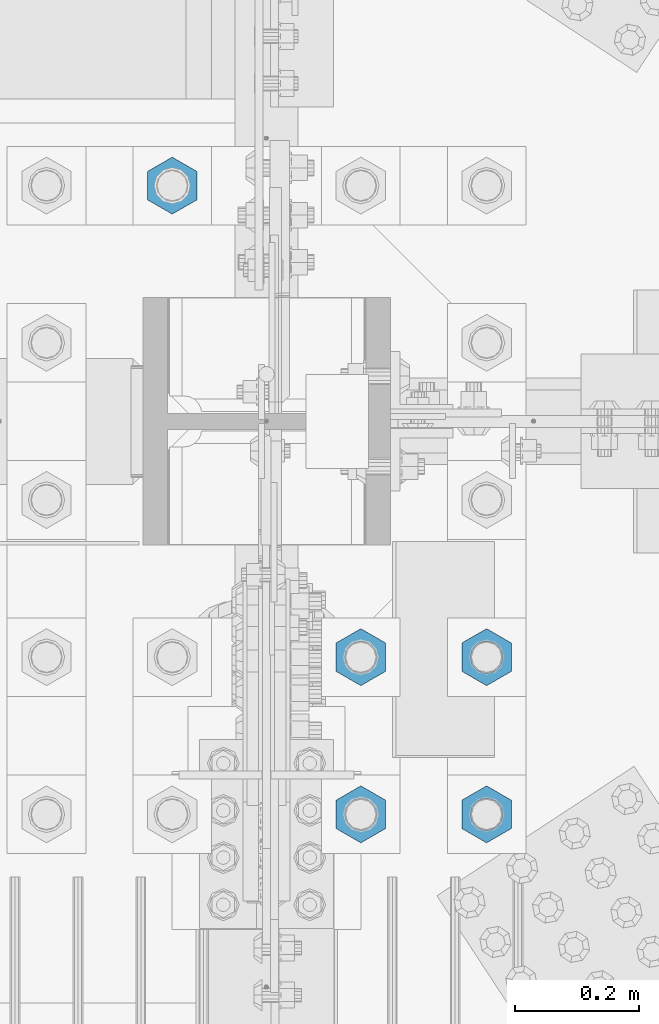
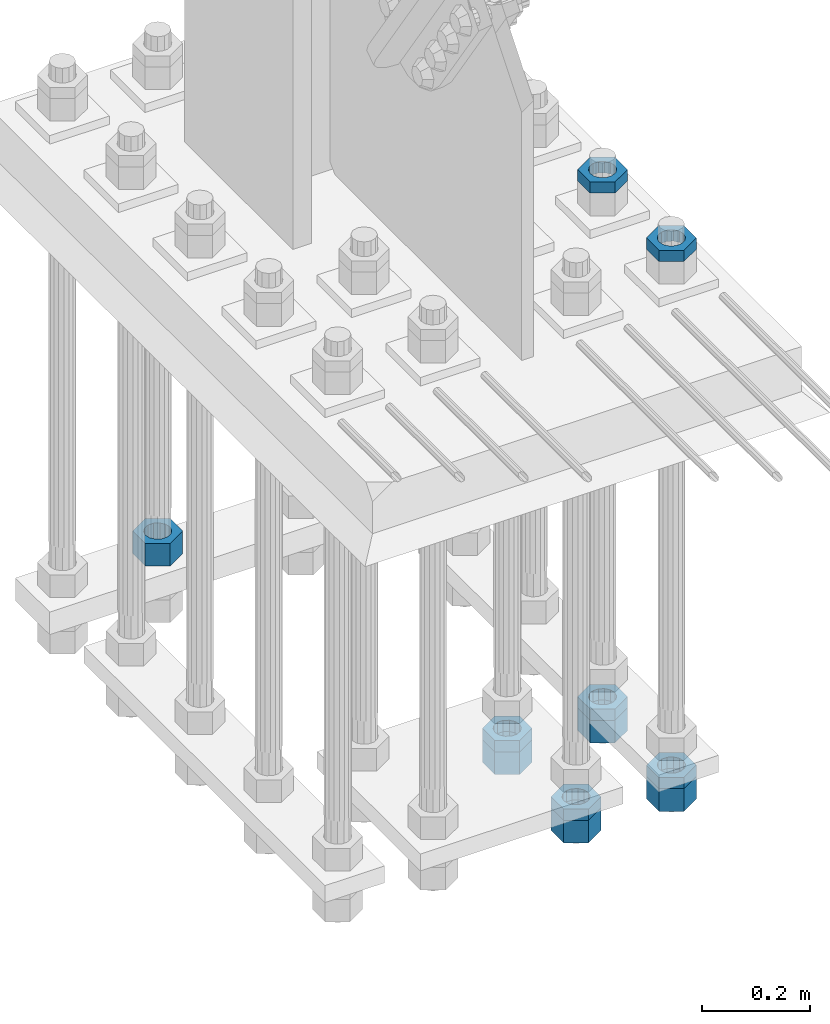
# One storey, part 2213 of 3843: 11 beams, 1 element without a shape of its own.
"""IFC2X3 building model written with IfcOpenShell, lengths in millimetres."""

from ifc_helpers import new_model, si_unit, frame, origin_with_axes, place, context, subcontext, project, spatial, faceted_brep, material, type_object, element, aggregate, save


model = new_model("IFC2X3")

# Units and contexts
model_context = context("Model", 3, precision=1e-05, world=origin_with_axes())
body_context = subcontext(model_context, "Body", "Model", "MODEL_VIEW")
ifc_project = project(units=[si_unit("LENGTHUNIT", "METRE", prefix="MILLI"), si_unit("AREAUNIT", "SQUARE_METRE"), si_unit("VOLUMEUNIT", "CUBIC_METRE"), si_unit("MASSUNIT", "GRAM", prefix="KILO"), si_unit("TIMEUNIT", "SECOND"), si_unit("PLANEANGLEUNIT", "RADIAN"), si_unit("SOLIDANGLEUNIT", "STERADIAN"), si_unit("THERMODYNAMICTEMPERATUREUNIT", "DEGREE_CELSIUS"), si_unit("LUMINOUSINTENSITYUNIT", "LUMEN")], contexts=[model_context])

# Site, building, storey
site_placement = place(None, origin_with_axes())
site = spatial("IfcSite", under=ifc_project, at=site_placement, CompositionType="ELEMENT")
building_placement = place(site_placement, origin_with_axes())
building = spatial("IfcBuilding", under=site, at=building_placement, Name="Undefined", CompositionType="ELEMENT")
storey_placement = place(building_placement, origin_with_axes())
storey = spatial("IfcBuildingStorey", under=building, at=storey_placement, Name="Undefined", CompositionType="ELEMENT", Elevation=0.0)

# Assembly, beams
assembly_placement = place(storey_placement, origin_with_axes())
assembly = element("IfcElementAssembly", 1, at=assembly_placement, inside=storey, Name="TEMPLATE", AssemblyPlace="NOTDEFINED", PredefinedType="RIGID_FRAME")
ifc_material = material(Name="STEEL/A572-50")
beam_type_1 = type_object("IfcBeamType", Name="2_HALF_NUT", PredefinedType="NOTDEFINED")
beam_1_placement = place(assembly_placement, frame((36931.6, 58534.3, 30257.75), z_axis=(-1.0, 0.0, 0.0), x_axis=(0.0, 0.0, -1.0)))
beam_1 = element("IfcBeam", 2, at=beam_1_placement, type_object=beam_type_1, material=ifc_material, Name="NUT", ObjectType="2_HALF_NUT", context=body_context, shape_type="Brep", body=[
    faceted_brep([(0.0, -46.0369987487793, 0.0), (0.0, -23.0184993743896, -39.869213104248), (25.4000000000015, -23.0184993743896, -39.869213104248), (25.4000000000015, -46.0369987487793, 0.0), (0.0, 23.0184993743896, -39.869213104248), (25.4000000000015, 23.0184993743896, -39.869213104248), (0.0, 46.0369987487793, 0.0), (25.4000000000015, 46.0369987487793, 0.0), (0.0, 23.0184993743896, 39.869213104248), (25.4000000000015, 23.0184993743896, 39.869213104248), (0.0, -23.0184993743896, 39.869213104248), (25.4000000000015, -23.0184993743896, 39.869213104248), (0.0, 0.0, 26.1940002441406), (0.0, 11.3650617044477, 23.5999013092805), (25.4000000000015, 11.3650617044477, 23.5999013092805), (25.4000000000015, 0.0, 26.1940002441406), (0.0, 20.4791109456419, 16.3316083006721), (25.4000000000015, 20.4791109456419, 16.3316083006721), (0.0, 25.5370200498292, 5.82867859874386), (25.4000000000015, 25.5370200498292, 5.82867859874386), (0.0, 25.5370200498292, -5.82867859874386), (25.4000000000015, 25.5370200498292, -5.82867859874386), (0.0, 20.4791109456419, -16.3316083006721), (25.4000000000015, 20.4791109456419, -16.3316083006721), (0.0, 11.3650617044477, -23.5999013092805), (25.4000000000015, 11.3650617044477, -23.5999013092805), (0.0, 0.0, -26.1940002441406), (25.4000000000015, 0.0, -26.1940002441406), (0.0, -11.3650617044477, -23.5999013092805), (25.4000000000015, -11.3650617044477, -23.5999013092805), (0.0, -20.4791109456419, -16.3316083006721), (25.4000000000015, -20.4791109456419, -16.3316083006721), (0.0, -25.5370200498292, -5.82867859874386), (25.4000000000015, -25.5370200498292, -5.82867859874386), (0.0, -25.5370200498292, 5.82867859874386), (25.4000000000015, -25.5370200498292, 5.82867859874386), (0.0, -20.4791109456419, 16.3316083006721), (25.4000000000015, -20.4791109456419, 16.3316083006721), (0.0, -11.3650617044477, 23.5999013092805), (25.4000000000015, -11.3650617044477, 23.5999013092805)], [[[0, 1, 2, 3]], [[1, 4, 5, 2]], [[4, 6, 7, 5]], [[6, 8, 9, 7]], [[8, 10, 11, 9]], [[10, 0, 3, 11]], [[12, 13, 14, 15]], [[13, 16, 17, 14]], [[16, 18, 19, 17]], [[18, 20, 21, 19]], [[20, 22, 23, 21]], [[22, 24, 25, 23]], [[24, 26, 27, 25]], [[26, 28, 29, 27]], [[28, 30, 31, 29]], [[30, 32, 33, 31]], [[32, 34, 35, 33]], [[34, 36, 37, 35]], [[36, 38, 39, 37]], [[38, 12, 15, 39]], [[5, 7, 9, 11, 3, 2], [17, 19, 21, 23, 25, 27, 29, 31, 33, 35, 37, 39, 15, 14]], [[10, 8, 6, 4, 1, 0], [38, 36, 34, 32, 30, 28, 26, 24, 22, 20, 18, 16, 13, 12]]]),
])
beam_2_placement = place(assembly_placement, frame((36931.6, 58280.3, 30257.75), z_axis=(-1.0, 0.0, 0.0), x_axis=(0.0, 0.0, -1.0)))
beam_2 = element("IfcBeam", 3, at=beam_2_placement, type_object=beam_type_1, material=ifc_material, Name="NUT", ObjectType="2_HALF_NUT", context=body_context, shape_type="Brep", body=[
    faceted_brep([(0.0, -46.0369987487793, 0.0), (0.0, -23.0184993743896, -39.869213104248), (25.4000000000015, -23.0184993743896, -39.869213104248), (25.4000000000015, -46.0369987487793, 0.0), (0.0, 23.0184993743896, -39.869213104248), (25.4000000000015, 23.0184993743896, -39.869213104248), (0.0, 46.0369987487793, 0.0), (25.4000000000015, 46.0369987487793, 0.0), (0.0, 23.0184993743896, 39.869213104248), (25.4000000000015, 23.0184993743896, 39.869213104248), (0.0, -23.0184993743896, 39.869213104248), (25.4000000000015, -23.0184993743896, 39.869213104248), (0.0, 0.0, 26.1940002441406), (0.0, 11.3650617044477, 23.5999013092805), (25.4000000000015, 11.3650617044477, 23.5999013092805), (25.4000000000015, 0.0, 26.1940002441406), (0.0, 20.4791109456419, 16.3316083006721), (25.4000000000015, 20.4791109456419, 16.3316083006721), (0.0, 25.5370200498292, 5.82867859874386), (25.4000000000015, 25.5370200498292, 5.82867859874386), (0.0, 25.5370200498292, -5.82867859874386), (25.4000000000015, 25.5370200498292, -5.82867859874386), (0.0, 20.4791109456419, -16.3316083006721), (25.4000000000015, 20.4791109456419, -16.3316083006721), (0.0, 11.3650617044477, -23.5999013092805), (25.4000000000015, 11.3650617044477, -23.5999013092805), (0.0, 0.0, -26.1940002441406), (25.4000000000015, 0.0, -26.1940002441406), (0.0, -11.3650617044477, -23.5999013092805), (25.4000000000015, -11.3650617044477, -23.5999013092805), (0.0, -20.4791109456419, -16.3316083006721), (25.4000000000015, -20.4791109456419, -16.3316083006721), (0.0, -25.5370200498292, -5.82867859874386), (25.4000000000015, -25.5370200498292, -5.82867859874386), (0.0, -25.5370200498292, 5.82867859874386), (25.4000000000015, -25.5370200498292, 5.82867859874386), (0.0, -20.4791109456419, 16.3316083006721), (25.4000000000015, -20.4791109456419, 16.3316083006721), (0.0, -11.3650617044477, 23.5999013092805), (25.4000000000015, -11.3650617044477, 23.5999013092805)], [[[0, 1, 2, 3]], [[1, 4, 5, 2]], [[4, 6, 7, 5]], [[6, 8, 9, 7]], [[8, 10, 11, 9]], [[10, 0, 3, 11]], [[12, 13, 14, 15]], [[13, 16, 17, 14]], [[16, 18, 19, 17]], [[18, 20, 21, 19]], [[20, 22, 23, 21]], [[22, 24, 25, 23]], [[24, 26, 27, 25]], [[26, 28, 29, 27]], [[28, 30, 31, 29]], [[30, 32, 33, 31]], [[32, 34, 35, 33]], [[34, 36, 37, 35]], [[36, 38, 39, 37]], [[38, 12, 15, 39]], [[5, 7, 9, 11, 3, 2], [17, 19, 21, 23, 25, 27, 29, 31, 33, 35, 37, 39, 15, 14]], [[10, 8, 6, 4, 1, 0], [38, 36, 34, 32, 30, 28, 26, 24, 22, 20, 18, 16, 13, 12]]]),
])
beam_3_placement = place(assembly_placement, frame((36728.4, 58534.3, 29070.3), z_axis=(-1.0, 0.0, 0.0), x_axis=(0.0, 0.0, -1.0)))
beam_3 = element("IfcBeam", 4, at=beam_3_placement, type_object=beam_type_1, material=ifc_material, Name="NUT", ObjectType="2_HALF_NUT", context=body_context, shape_type="Brep", body=[
    faceted_brep([(0.0, -46.0369987487793, 0.0), (0.0, -23.0184993743896, -39.869213104248), (25.4000000000015, -23.0184993743896, -39.869213104248), (25.4000000000015, -46.0369987487793, 0.0), (0.0, 23.0184993743896, -39.869213104248), (25.4000000000015, 23.0184993743896, -39.869213104248), (0.0, 46.0369987487793, 0.0), (25.4000000000015, 46.0369987487793, 0.0), (0.0, 23.0184993743896, 39.869213104248), (25.4000000000015, 23.0184993743896, 39.869213104248), (0.0, -23.0184993743896, 39.869213104248), (25.4000000000015, -23.0184993743896, 39.869213104248), (0.0, 0.0, 26.1940002441406), (0.0, 11.3650617044477, 23.5999013092805), (25.4000000000015, 11.3650617044477, 23.5999013092805), (25.4000000000015, 0.0, 26.1940002441406), (0.0, 20.4791109456419, 16.3316083006721), (25.4000000000015, 20.4791109456419, 16.3316083006721), (0.0, 25.5370200498292, 5.82867859874386), (25.4000000000015, 25.5370200498292, 5.82867859874386), (0.0, 25.5370200498292, -5.82867859874386), (25.4000000000015, 25.5370200498292, -5.82867859874386), (0.0, 20.4791109456419, -16.3316083006721), (25.4000000000015, 20.4791109456419, -16.3316083006721), (0.0, 11.3650617044477, -23.5999013092805), (25.4000000000015, 11.3650617044477, -23.5999013092805), (0.0, 0.0, -26.1940002441406), (25.4000000000015, 0.0, -26.1940002441406), (0.0, -11.3650617044477, -23.5999013092805), (25.4000000000015, -11.3650617044477, -23.5999013092805), (0.0, -20.4791109456419, -16.3316083006721), (25.4000000000015, -20.4791109456419, -16.3316083006721), (0.0, -25.5370200498292, -5.82867859874386), (25.4000000000015, -25.5370200498292, -5.82867859874386), (0.0, -25.5370200498292, 5.82867859874386), (25.4000000000015, -25.5370200498292, 5.82867859874386), (0.0, -20.4791109456419, 16.3316083006721), (25.4000000000015, -20.4791109456419, 16.3316083006721), (0.0, -11.3650617044477, 23.5999013092805), (25.4000000000015, -11.3650617044477, 23.5999013092805)], [[[0, 1, 2, 3]], [[1, 4, 5, 2]], [[4, 6, 7, 5]], [[6, 8, 9, 7]], [[8, 10, 11, 9]], [[10, 0, 3, 11]], [[12, 13, 14, 15]], [[13, 16, 17, 14]], [[16, 18, 19, 17]], [[18, 20, 21, 19]], [[20, 22, 23, 21]], [[22, 24, 25, 23]], [[24, 26, 27, 25]], [[26, 28, 29, 27]], [[28, 30, 31, 29]], [[30, 32, 33, 31]], [[32, 34, 35, 33]], [[34, 36, 37, 35]], [[36, 38, 39, 37]], [[38, 12, 15, 39]], [[5, 7, 9, 11, 3, 2], [17, 19, 21, 23, 25, 27, 29, 31, 33, 35, 37, 39, 15, 14]], [[10, 8, 6, 4, 1, 0], [38, 36, 34, 32, 30, 28, 26, 24, 22, 20, 18, 16, 13, 12]]]),
])
beam_4_placement = place(assembly_placement, frame((36728.4, 58280.3, 29070.3), z_axis=(-1.0, 0.0, 0.0), x_axis=(0.0, 0.0, -1.0)))
beam_4 = element("IfcBeam", 5, at=beam_4_placement, type_object=beam_type_1, material=ifc_material, Name="NUT", ObjectType="2_HALF_NUT", context=body_context, shape_type="Brep", body=[
    faceted_brep([(0.0, -46.0369987487793, 0.0), (0.0, -23.0184993743896, -39.869213104248), (25.4000000000015, -23.0184993743896, -39.869213104248), (25.4000000000015, -46.0369987487793, 0.0), (0.0, 23.0184993743896, -39.869213104248), (25.4000000000015, 23.0184993743896, -39.869213104248), (0.0, 46.0369987487793, 0.0), (25.4000000000015, 46.0369987487793, 0.0), (0.0, 23.0184993743896, 39.869213104248), (25.4000000000015, 23.0184993743896, 39.869213104248), (0.0, -23.0184993743896, 39.869213104248), (25.4000000000015, -23.0184993743896, 39.869213104248), (0.0, 0.0, 26.1940002441406), (0.0, 11.3650617044477, 23.5999013092805), (25.4000000000015, 11.3650617044477, 23.5999013092805), (25.4000000000015, 0.0, 26.1940002441406), (0.0, 20.4791109456419, 16.3316083006721), (25.4000000000015, 20.4791109456419, 16.3316083006721), (0.0, 25.5370200498292, 5.82867859874386), (25.4000000000015, 25.5370200498292, 5.82867859874386), (0.0, 25.5370200498292, -5.82867859874386), (25.4000000000015, 25.5370200498292, -5.82867859874386), (0.0, 20.4791109456419, -16.3316083006721), (25.4000000000015, 20.4791109456419, -16.3316083006721), (0.0, 11.3650617044477, -23.5999013092805), (25.4000000000015, 11.3650617044477, -23.5999013092805), (0.0, 0.0, -26.1940002441406), (25.4000000000015, 0.0, -26.1940002441406), (0.0, -11.3650617044477, -23.5999013092805), (25.4000000000015, -11.3650617044477, -23.5999013092805), (0.0, -20.4791109456419, -16.3316083006721), (25.4000000000015, -20.4791109456419, -16.3316083006721), (0.0, -25.5370200498292, -5.82867859874386), (25.4000000000015, -25.5370200498292, -5.82867859874386), (0.0, -25.5370200498292, 5.82867859874386), (25.4000000000015, -25.5370200498292, 5.82867859874386), (0.0, -20.4791109456419, 16.3316083006721), (25.4000000000015, -20.4791109456419, 16.3316083006721), (0.0, -11.3650617044477, 23.5999013092805), (25.4000000000015, -11.3650617044477, 23.5999013092805)], [[[0, 1, 2, 3]], [[1, 4, 5, 2]], [[4, 6, 7, 5]], [[6, 8, 9, 7]], [[8, 10, 11, 9]], [[10, 0, 3, 11]], [[12, 13, 14, 15]], [[13, 16, 17, 14]], [[16, 18, 19, 17]], [[18, 20, 21, 19]], [[20, 22, 23, 21]], [[22, 24, 25, 23]], [[24, 26, 27, 25]], [[26, 28, 29, 27]], [[28, 30, 31, 29]], [[30, 32, 33, 31]], [[32, 34, 35, 33]], [[34, 36, 37, 35]], [[36, 38, 39, 37]], [[38, 12, 15, 39]], [[5, 7, 9, 11, 3, 2], [17, 19, 21, 23, 25, 27, 29, 31, 33, 35, 37, 39, 15, 14]], [[10, 8, 6, 4, 1, 0], [38, 36, 34, 32, 30, 28, 26, 24, 22, 20, 18, 16, 13, 12]]]),
])
beam_5_placement = place(assembly_placement, frame((36931.6, 58534.3, 29070.3), z_axis=(-1.0, 0.0, 0.0), x_axis=(0.0, 0.0, -1.0)))
beam_5 = element("IfcBeam", 6, at=beam_5_placement, type_object=beam_type_1, material=ifc_material, Name="NUT", ObjectType="2_HALF_NUT", context=body_context, shape_type="Brep", body=[
    faceted_brep([(0.0, -46.0369987487793, 0.0), (0.0, -23.0184993743896, -39.869213104248), (25.4000000000015, -23.0184993743896, -39.869213104248), (25.4000000000015, -46.0369987487793, 0.0), (0.0, 23.0184993743896, -39.869213104248), (25.4000000000015, 23.0184993743896, -39.869213104248), (0.0, 46.0369987487793, 0.0), (25.4000000000015, 46.0369987487793, 0.0), (0.0, 23.0184993743896, 39.869213104248), (25.4000000000015, 23.0184993743896, 39.869213104248), (0.0, -23.0184993743896, 39.869213104248), (25.4000000000015, -23.0184993743896, 39.869213104248), (0.0, 0.0, 26.1940002441406), (0.0, 11.3650617044477, 23.5999013092805), (25.4000000000015, 11.3650617044477, 23.5999013092805), (25.4000000000015, 0.0, 26.1940002441406), (0.0, 20.4791109456419, 16.3316083006721), (25.4000000000015, 20.4791109456419, 16.3316083006721), (0.0, 25.5370200498292, 5.82867859874386), (25.4000000000015, 25.5370200498292, 5.82867859874386), (0.0, 25.5370200498292, -5.82867859874386), (25.4000000000015, 25.5370200498292, -5.82867859874386), (0.0, 20.4791109456419, -16.3316083006721), (25.4000000000015, 20.4791109456419, -16.3316083006721), (0.0, 11.3650617044477, -23.5999013092805), (25.4000000000015, 11.3650617044477, -23.5999013092805), (0.0, 0.0, -26.1940002441406), (25.4000000000015, 0.0, -26.1940002441406), (0.0, -11.3650617044477, -23.5999013092805), (25.4000000000015, -11.3650617044477, -23.5999013092805), (0.0, -20.4791109456419, -16.3316083006721), (25.4000000000015, -20.4791109456419, -16.3316083006721), (0.0, -25.5370200498292, -5.82867859874386), (25.4000000000015, -25.5370200498292, -5.82867859874386), (0.0, -25.5370200498292, 5.82867859874386), (25.4000000000015, -25.5370200498292, 5.82867859874386), (0.0, -20.4791109456419, 16.3316083006721), (25.4000000000015, -20.4791109456419, 16.3316083006721), (0.0, -11.3650617044477, 23.5999013092805), (25.4000000000015, -11.3650617044477, 23.5999013092805)], [[[0, 1, 2, 3]], [[1, 4, 5, 2]], [[4, 6, 7, 5]], [[6, 8, 9, 7]], [[8, 10, 11, 9]], [[10, 0, 3, 11]], [[12, 13, 14, 15]], [[13, 16, 17, 14]], [[16, 18, 19, 17]], [[18, 20, 21, 19]], [[20, 22, 23, 21]], [[22, 24, 25, 23]], [[24, 26, 27, 25]], [[26, 28, 29, 27]], [[28, 30, 31, 29]], [[30, 32, 33, 31]], [[32, 34, 35, 33]], [[34, 36, 37, 35]], [[36, 38, 39, 37]], [[38, 12, 15, 39]], [[5, 7, 9, 11, 3, 2], [17, 19, 21, 23, 25, 27, 29, 31, 33, 35, 37, 39, 15, 14]], [[10, 8, 6, 4, 1, 0], [38, 36, 34, 32, 30, 28, 26, 24, 22, 20, 18, 16, 13, 12]]]),
])
beam_6_placement = place(assembly_placement, frame((36931.6, 58280.3, 29070.3), z_axis=(-1.0, 0.0, 0.0), x_axis=(0.0, 0.0, -1.0)))
beam_6 = element("IfcBeam", 7, at=beam_6_placement, type_object=beam_type_1, material=ifc_material, Name="NUT", ObjectType="2_HALF_NUT", context=body_context, shape_type="Brep", body=[
    faceted_brep([(0.0, -46.0369987487793, 0.0), (0.0, -23.0184993743896, -39.869213104248), (25.4000000000015, -23.0184993743896, -39.869213104248), (25.4000000000015, -46.0369987487793, 0.0), (0.0, 23.0184993743896, -39.869213104248), (25.4000000000015, 23.0184993743896, -39.869213104248), (0.0, 46.0369987487793, 0.0), (25.4000000000015, 46.0369987487793, 0.0), (0.0, 23.0184993743896, 39.869213104248), (25.4000000000015, 23.0184993743896, 39.869213104248), (0.0, -23.0184993743896, 39.869213104248), (25.4000000000015, -23.0184993743896, 39.869213104248), (0.0, 0.0, 26.1940002441406), (0.0, 11.3650617044477, 23.5999013092805), (25.4000000000015, 11.3650617044477, 23.5999013092805), (25.4000000000015, 0.0, 26.1940002441406), (0.0, 20.4791109456419, 16.3316083006721), (25.4000000000015, 20.4791109456419, 16.3316083006721), (0.0, 25.5370200498292, 5.82867859874386), (25.4000000000015, 25.5370200498292, 5.82867859874386), (0.0, 25.5370200498292, -5.82867859874386), (25.4000000000015, 25.5370200498292, -5.82867859874386), (0.0, 20.4791109456419, -16.3316083006721), (25.4000000000015, 20.4791109456419, -16.3316083006721), (0.0, 11.3650617044477, -23.5999013092805), (25.4000000000015, 11.3650617044477, -23.5999013092805), (0.0, 0.0, -26.1940002441406), (25.4000000000015, 0.0, -26.1940002441406), (0.0, -11.3650617044477, -23.5999013092805), (25.4000000000015, -11.3650617044477, -23.5999013092805), (0.0, -20.4791109456419, -16.3316083006721), (25.4000000000015, -20.4791109456419, -16.3316083006721), (0.0, -25.5370200498292, -5.82867859874386), (25.4000000000015, -25.5370200498292, -5.82867859874386), (0.0, -25.5370200498292, 5.82867859874386), (25.4000000000015, -25.5370200498292, 5.82867859874386), (0.0, -20.4791109456419, 16.3316083006721), (25.4000000000015, -20.4791109456419, 16.3316083006721), (0.0, -11.3650617044477, 23.5999013092805), (25.4000000000015, -11.3650617044477, 23.5999013092805)], [[[0, 1, 2, 3]], [[1, 4, 5, 2]], [[4, 6, 7, 5]], [[6, 8, 9, 7]], [[8, 10, 11, 9]], [[10, 0, 3, 11]], [[12, 13, 14, 15]], [[13, 16, 17, 14]], [[16, 18, 19, 17]], [[18, 20, 21, 19]], [[20, 22, 23, 21]], [[22, 24, 25, 23]], [[24, 26, 27, 25]], [[26, 28, 29, 27]], [[28, 30, 31, 29]], [[30, 32, 33, 31]], [[32, 34, 35, 33]], [[34, 36, 37, 35]], [[36, 38, 39, 37]], [[38, 12, 15, 39]], [[5, 7, 9, 11, 3, 2], [17, 19, 21, 23, 25, 27, 29, 31, 33, 35, 37, 39, 15, 14]], [[10, 8, 6, 4, 1, 0], [38, 36, 34, 32, 30, 28, 26, 24, 22, 20, 18, 16, 13, 12]]]),
])
beam_type_2 = type_object("IfcBeamType", Name="2_HEAVY_HEX_NUT", PredefinedType="NOTDEFINED")
beam_7_placement = place(assembly_placement, frame((36423.6, 59296.3, 29159.2), z_axis=(1.0, 0.0, 0.0), x_axis=(0.0, 0.0, -1.0)))
beam_7 = element("IfcBeam", 8, at=beam_7_placement, type_object=beam_type_2, material=ifc_material, Name="NUT", ObjectType="2_HEAVY_HEX_NUT", context=body_context, shape_type="Brep", body=[
    faceted_brep([(0.0, -46.0369987487793, 0.0), (0.0, -23.0184993743896, -39.869213104248), (50.7999999999993, -23.0184993743896, -39.869213104248), (50.7999999999993, -46.0369987487793, 0.0), (0.0, 23.0184993743896, -39.869213104248), (50.7999999999993, 23.0184993743896, -39.869213104248), (0.0, 46.0369987487793, 0.0), (50.7999999999993, 46.0369987487793, 0.0), (0.0, 23.0184993743896, 39.869213104248), (50.7999999999993, 23.0184993743896, 39.869213104248), (0.0, -23.0184993743896, 39.869213104248), (50.7999999999993, -23.0184993743896, 39.869213104248), (0.0, 0.0, 26.1940002441406), (0.0, 11.3650617044477, 23.5999013092805), (50.7999999999993, 11.3650617044477, 23.5999013092805), (50.7999999999993, 0.0, 26.1940002441406), (0.0, 20.4791109456419, 16.3316083006721), (50.7999999999993, 20.4791109456419, 16.3316083006721), (0.0, 25.5370200498292, 5.82867859874386), (50.7999999999993, 25.5370200498292, 5.82867859874386), (0.0, 25.5370200498292, -5.82867859874386), (50.7999999999993, 25.5370200498292, -5.82867859874386), (0.0, 20.4791109456419, -16.3316083006721), (50.7999999999993, 20.4791109456419, -16.3316083006721), (0.0, 11.3650617044477, -23.5999013092805), (50.7999999999993, 11.3650617044477, -23.5999013092805), (0.0, 0.0, -26.1940002441406), (50.7999999999993, 0.0, -26.1940002441406), (0.0, -11.3650617044477, -23.5999013092805), (50.7999999999993, -11.3650617044477, -23.5999013092805), (0.0, -20.4791109456419, -16.3316083006721), (50.7999999999993, -20.4791109456419, -16.3316083006721), (0.0, -25.5370200498292, -5.82867859874386), (50.7999999999993, -25.5370200498292, -5.82867859874386), (0.0, -25.5370200498292, 5.82867859874386), (50.7999999999993, -25.5370200498292, 5.82867859874386), (0.0, -20.4791109456419, 16.3316083006721), (50.7999999999993, -20.4791109456419, 16.3316083006721), (0.0, -11.3650617044477, 23.5999013092805), (50.7999999999993, -11.3650617044477, 23.5999013092805)], [[[0, 1, 2, 3]], [[1, 4, 5, 2]], [[4, 6, 7, 5]], [[6, 8, 9, 7]], [[8, 10, 11, 9]], [[10, 0, 3, 11]], [[12, 13, 14, 15]], [[13, 16, 17, 14]], [[16, 18, 19, 17]], [[18, 20, 21, 19]], [[20, 22, 23, 21]], [[22, 24, 25, 23]], [[24, 26, 27, 25]], [[26, 28, 29, 27]], [[28, 30, 31, 29]], [[30, 32, 33, 31]], [[32, 34, 35, 33]], [[34, 36, 37, 35]], [[36, 38, 39, 37]], [[38, 12, 15, 39]], [[5, 7, 9, 11, 3, 2], [17, 19, 21, 23, 25, 27, 29, 31, 33, 35, 37, 39, 15, 14]], [[10, 8, 6, 4, 1, 0], [38, 36, 34, 32, 30, 28, 26, 24, 22, 20, 18, 16, 13, 12]]]),
])
beam_8_placement = place(assembly_placement, frame((36728.4, 58534.3, 29044.9), z_axis=(-1.0, 0.0, 0.0), x_axis=(0.0, 0.0, -1.0)))
beam_8 = element("IfcBeam", 9, at=beam_8_placement, type_object=beam_type_2, material=ifc_material, Name="NUT", ObjectType="2_HEAVY_HEX_NUT", context=body_context, shape_type="Brep", body=[
    faceted_brep([(0.0, -46.0369987487793, 0.0), (0.0, -23.0184993743896, -39.869213104248), (50.7999999999993, -23.0184993743896, -39.869213104248), (50.7999999999993, -46.0369987487793, 0.0), (0.0, 23.0184993743896, -39.869213104248), (50.7999999999993, 23.0184993743896, -39.869213104248), (0.0, 46.0369987487793, 0.0), (50.7999999999993, 46.0369987487793, 0.0), (0.0, 23.0184993743896, 39.869213104248), (50.7999999999993, 23.0184993743896, 39.869213104248), (0.0, -23.0184993743896, 39.869213104248), (50.7999999999993, -23.0184993743896, 39.869213104248), (0.0, 0.0, 26.1940002441406), (0.0, 11.3650617044477, 23.5999013092805), (50.7999999999993, 11.3650617044477, 23.5999013092805), (50.7999999999993, 0.0, 26.1940002441406), (0.0, 20.4791109456419, 16.3316083006721), (50.7999999999993, 20.4791109456419, 16.3316083006721), (0.0, 25.5370200498292, 5.82867859874386), (50.7999999999993, 25.5370200498292, 5.82867859874386), (0.0, 25.5370200498292, -5.82867859874386), (50.7999999999993, 25.5370200498292, -5.82867859874386), (0.0, 20.4791109456419, -16.3316083006721), (50.7999999999993, 20.4791109456419, -16.3316083006721), (0.0, 11.3650617044477, -23.5999013092805), (50.7999999999993, 11.3650617044477, -23.5999013092805), (0.0, 0.0, -26.1940002441406), (50.7999999999993, 0.0, -26.1940002441406), (0.0, -11.3650617044477, -23.5999013092805), (50.7999999999993, -11.3650617044477, -23.5999013092805), (0.0, -20.4791109456419, -16.3316083006721), (50.7999999999993, -20.4791109456419, -16.3316083006721), (0.0, -25.5370200498292, -5.82867859874386), (50.7999999999993, -25.5370200498292, -5.82867859874386), (0.0, -25.5370200498292, 5.82867859874386), (50.7999999999993, -25.5370200498292, 5.82867859874386), (0.0, -20.4791109456419, 16.3316083006721), (50.7999999999993, -20.4791109456419, 16.3316083006721), (0.0, -11.3650617044477, 23.5999013092805), (50.7999999999993, -11.3650617044477, 23.5999013092805)], [[[0, 1, 2, 3]], [[1, 4, 5, 2]], [[4, 6, 7, 5]], [[6, 8, 9, 7]], [[8, 10, 11, 9]], [[10, 0, 3, 11]], [[12, 13, 14, 15]], [[13, 16, 17, 14]], [[16, 18, 19, 17]], [[18, 20, 21, 19]], [[20, 22, 23, 21]], [[22, 24, 25, 23]], [[24, 26, 27, 25]], [[26, 28, 29, 27]], [[28, 30, 31, 29]], [[30, 32, 33, 31]], [[32, 34, 35, 33]], [[34, 36, 37, 35]], [[36, 38, 39, 37]], [[38, 12, 15, 39]], [[5, 7, 9, 11, 3, 2], [17, 19, 21, 23, 25, 27, 29, 31, 33, 35, 37, 39, 15, 14]], [[10, 8, 6, 4, 1, 0], [38, 36, 34, 32, 30, 28, 26, 24, 22, 20, 18, 16, 13, 12]]]),
])
beam_9_placement = place(assembly_placement, frame((36728.4, 58280.3, 29044.9), z_axis=(-1.0, 0.0, 0.0), x_axis=(0.0, 0.0, -1.0)))
beam_9 = element("IfcBeam", 10, at=beam_9_placement, type_object=beam_type_2, material=ifc_material, Name="NUT", ObjectType="2_HEAVY_HEX_NUT", context=body_context, shape_type="Brep", body=[
    faceted_brep([(0.0, -46.0369987487793, 0.0), (0.0, -23.0184993743896, -39.869213104248), (50.7999999999993, -23.0184993743896, -39.869213104248), (50.7999999999993, -46.0369987487793, 0.0), (0.0, 23.0184993743896, -39.869213104248), (50.7999999999993, 23.0184993743896, -39.869213104248), (0.0, 46.0369987487793, 0.0), (50.7999999999993, 46.0369987487793, 0.0), (0.0, 23.0184993743896, 39.869213104248), (50.7999999999993, 23.0184993743896, 39.869213104248), (0.0, -23.0184993743896, 39.869213104248), (50.7999999999993, -23.0184993743896, 39.869213104248), (0.0, 0.0, 26.1940002441406), (0.0, 11.3650617044477, 23.5999013092805), (50.7999999999993, 11.3650617044477, 23.5999013092805), (50.7999999999993, 0.0, 26.1940002441406), (0.0, 20.4791109456419, 16.3316083006721), (50.7999999999993, 20.4791109456419, 16.3316083006721), (0.0, 25.5370200498292, 5.82867859874386), (50.7999999999993, 25.5370200498292, 5.82867859874386), (0.0, 25.5370200498292, -5.82867859874386), (50.7999999999993, 25.5370200498292, -5.82867859874386), (0.0, 20.4791109456419, -16.3316083006721), (50.7999999999993, 20.4791109456419, -16.3316083006721), (0.0, 11.3650617044477, -23.5999013092805), (50.7999999999993, 11.3650617044477, -23.5999013092805), (0.0, 0.0, -26.1940002441406), (50.7999999999993, 0.0, -26.1940002441406), (0.0, -11.3650617044477, -23.5999013092805), (50.7999999999993, -11.3650617044477, -23.5999013092805), (0.0, -20.4791109456419, -16.3316083006721), (50.7999999999993, -20.4791109456419, -16.3316083006721), (0.0, -25.5370200498292, -5.82867859874386), (50.7999999999993, -25.5370200498292, -5.82867859874386), (0.0, -25.5370200498292, 5.82867859874386), (50.7999999999993, -25.5370200498292, 5.82867859874386), (0.0, -20.4791109456419, 16.3316083006721), (50.7999999999993, -20.4791109456419, 16.3316083006721), (0.0, -11.3650617044477, 23.5999013092805), (50.7999999999993, -11.3650617044477, 23.5999013092805)], [[[0, 1, 2, 3]], [[1, 4, 5, 2]], [[4, 6, 7, 5]], [[6, 8, 9, 7]], [[8, 10, 11, 9]], [[10, 0, 3, 11]], [[12, 13, 14, 15]], [[13, 16, 17, 14]], [[16, 18, 19, 17]], [[18, 20, 21, 19]], [[20, 22, 23, 21]], [[22, 24, 25, 23]], [[24, 26, 27, 25]], [[26, 28, 29, 27]], [[28, 30, 31, 29]], [[30, 32, 33, 31]], [[32, 34, 35, 33]], [[34, 36, 37, 35]], [[36, 38, 39, 37]], [[38, 12, 15, 39]], [[5, 7, 9, 11, 3, 2], [17, 19, 21, 23, 25, 27, 29, 31, 33, 35, 37, 39, 15, 14]], [[10, 8, 6, 4, 1, 0], [38, 36, 34, 32, 30, 28, 26, 24, 22, 20, 18, 16, 13, 12]]]),
])
beam_10_placement = place(assembly_placement, frame((36931.6, 58534.3, 29044.9), z_axis=(-1.0, 0.0, 0.0), x_axis=(0.0, 0.0, -1.0)))
beam_10 = element("IfcBeam", 11, at=beam_10_placement, type_object=beam_type_2, material=ifc_material, Name="NUT", ObjectType="2_HEAVY_HEX_NUT", context=body_context, shape_type="Brep", body=[
    faceted_brep([(0.0, -46.0369987487793, 0.0), (0.0, -23.0184993743896, -39.869213104248), (50.7999999999993, -23.0184993743896, -39.869213104248), (50.7999999999993, -46.0369987487793, 0.0), (0.0, 23.0184993743896, -39.869213104248), (50.7999999999993, 23.0184993743896, -39.869213104248), (0.0, 46.0369987487793, 0.0), (50.7999999999993, 46.0369987487793, 0.0), (0.0, 23.0184993743896, 39.869213104248), (50.7999999999993, 23.0184993743896, 39.869213104248), (0.0, -23.0184993743896, 39.869213104248), (50.7999999999993, -23.0184993743896, 39.869213104248), (0.0, 0.0, 26.1940002441406), (0.0, 11.3650617044477, 23.5999013092805), (50.7999999999993, 11.3650617044477, 23.5999013092805), (50.7999999999993, 0.0, 26.1940002441406), (0.0, 20.4791109456419, 16.3316083006721), (50.7999999999993, 20.4791109456419, 16.3316083006721), (0.0, 25.5370200498292, 5.82867859874386), (50.7999999999993, 25.5370200498292, 5.82867859874386), (0.0, 25.5370200498292, -5.82867859874386), (50.7999999999993, 25.5370200498292, -5.82867859874386), (0.0, 20.4791109456419, -16.3316083006721), (50.7999999999993, 20.4791109456419, -16.3316083006721), (0.0, 11.3650617044477, -23.5999013092805), (50.7999999999993, 11.3650617044477, -23.5999013092805), (0.0, 0.0, -26.1940002441406), (50.7999999999993, 0.0, -26.1940002441406), (0.0, -11.3650617044477, -23.5999013092805), (50.7999999999993, -11.3650617044477, -23.5999013092805), (0.0, -20.4791109456419, -16.3316083006721), (50.7999999999993, -20.4791109456419, -16.3316083006721), (0.0, -25.5370200498292, -5.82867859874386), (50.7999999999993, -25.5370200498292, -5.82867859874386), (0.0, -25.5370200498292, 5.82867859874386), (50.7999999999993, -25.5370200498292, 5.82867859874386), (0.0, -20.4791109456419, 16.3316083006721), (50.7999999999993, -20.4791109456419, 16.3316083006721), (0.0, -11.3650617044477, 23.5999013092805), (50.7999999999993, -11.3650617044477, 23.5999013092805)], [[[0, 1, 2, 3]], [[1, 4, 5, 2]], [[4, 6, 7, 5]], [[6, 8, 9, 7]], [[8, 10, 11, 9]], [[10, 0, 3, 11]], [[12, 13, 14, 15]], [[13, 16, 17, 14]], [[16, 18, 19, 17]], [[18, 20, 21, 19]], [[20, 22, 23, 21]], [[22, 24, 25, 23]], [[24, 26, 27, 25]], [[26, 28, 29, 27]], [[28, 30, 31, 29]], [[30, 32, 33, 31]], [[32, 34, 35, 33]], [[34, 36, 37, 35]], [[36, 38, 39, 37]], [[38, 12, 15, 39]], [[5, 7, 9, 11, 3, 2], [17, 19, 21, 23, 25, 27, 29, 31, 33, 35, 37, 39, 15, 14]], [[10, 8, 6, 4, 1, 0], [38, 36, 34, 32, 30, 28, 26, 24, 22, 20, 18, 16, 13, 12]]]),
])
beam_11_placement = place(assembly_placement, frame((36931.6, 58280.3, 29044.9), z_axis=(-1.0, 0.0, 0.0), x_axis=(0.0, 0.0, -1.0)))
beam_11 = element("IfcBeam", 12, at=beam_11_placement, type_object=beam_type_2, material=ifc_material, Name="NUT", ObjectType="2_HEAVY_HEX_NUT", context=body_context, shape_type="Brep", body=[
    faceted_brep([(0.0, -46.0369987487793, 0.0), (0.0, -23.0184993743896, -39.869213104248), (50.7999999999993, -23.0184993743896, -39.869213104248), (50.7999999999993, -46.0369987487793, 0.0), (0.0, 23.0184993743896, -39.869213104248), (50.7999999999993, 23.0184993743896, -39.869213104248), (0.0, 46.0369987487793, 0.0), (50.7999999999993, 46.0369987487793, 0.0), (0.0, 23.0184993743896, 39.869213104248), (50.7999999999993, 23.0184993743896, 39.869213104248), (0.0, -23.0184993743896, 39.869213104248), (50.7999999999993, -23.0184993743896, 39.869213104248), (0.0, 0.0, 26.1940002441406), (0.0, 11.3650617044477, 23.5999013092805), (50.7999999999993, 11.3650617044477, 23.5999013092805), (50.7999999999993, 0.0, 26.1940002441406), (0.0, 20.4791109456419, 16.3316083006721), (50.7999999999993, 20.4791109456419, 16.3316083006721), (0.0, 25.5370200498292, 5.82867859874386), (50.7999999999993, 25.5370200498292, 5.82867859874386), (0.0, 25.5370200498292, -5.82867859874386), (50.7999999999993, 25.5370200498292, -5.82867859874386), (0.0, 20.4791109456419, -16.3316083006721), (50.7999999999993, 20.4791109456419, -16.3316083006721), (0.0, 11.3650617044477, -23.5999013092805), (50.7999999999993, 11.3650617044477, -23.5999013092805), (0.0, 0.0, -26.1940002441406), (50.7999999999993, 0.0, -26.1940002441406), (0.0, -11.3650617044477, -23.5999013092805), (50.7999999999993, -11.3650617044477, -23.5999013092805), (0.0, -20.4791109456419, -16.3316083006721), (50.7999999999993, -20.4791109456419, -16.3316083006721), (0.0, -25.5370200498292, -5.82867859874386), (50.7999999999993, -25.5370200498292, -5.82867859874386), (0.0, -25.5370200498292, 5.82867859874386), (50.7999999999993, -25.5370200498292, 5.82867859874386), (0.0, -20.4791109456419, 16.3316083006721), (50.7999999999993, -20.4791109456419, 16.3316083006721), (0.0, -11.3650617044477, 23.5999013092805), (50.7999999999993, -11.3650617044477, 23.5999013092805)], [[[0, 1, 2, 3]], [[1, 4, 5, 2]], [[4, 6, 7, 5]], [[6, 8, 9, 7]], [[8, 10, 11, 9]], [[10, 0, 3, 11]], [[12, 13, 14, 15]], [[13, 16, 17, 14]], [[16, 18, 19, 17]], [[18, 20, 21, 19]], [[20, 22, 23, 21]], [[22, 24, 25, 23]], [[24, 26, 27, 25]], [[26, 28, 29, 27]], [[28, 30, 31, 29]], [[30, 32, 33, 31]], [[32, 34, 35, 33]], [[34, 36, 37, 35]], [[36, 38, 39, 37]], [[38, 12, 15, 39]], [[5, 7, 9, 11, 3, 2], [17, 19, 21, 23, 25, 27, 29, 31, 33, 35, 37, 39, 15, 14]], [[10, 8, 6, 4, 1, 0], [38, 36, 34, 32, 30, 28, 26, 24, 22, 20, 18, 16, 13, 12]]]),
])
aggregate(assembly, [beam_7, beam_1, beam_2, beam_8, beam_3, beam_9, beam_4, beam_10, beam_11, beam_5, beam_6])

save(model, "model.ifc")
